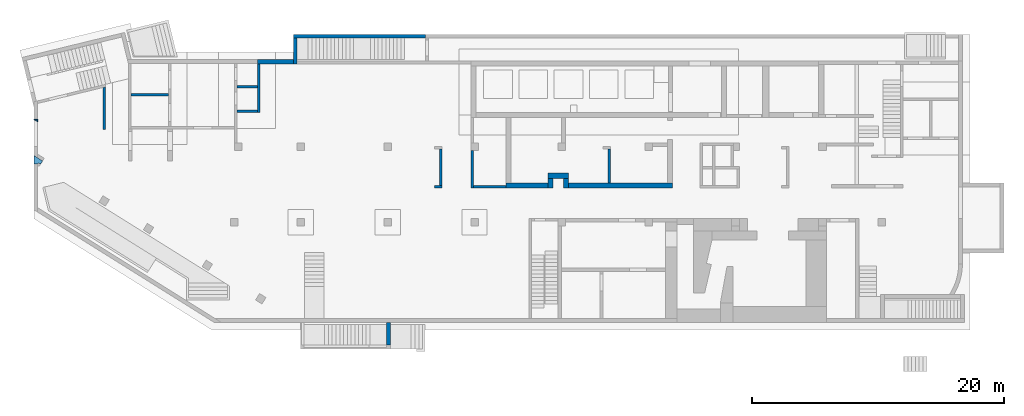
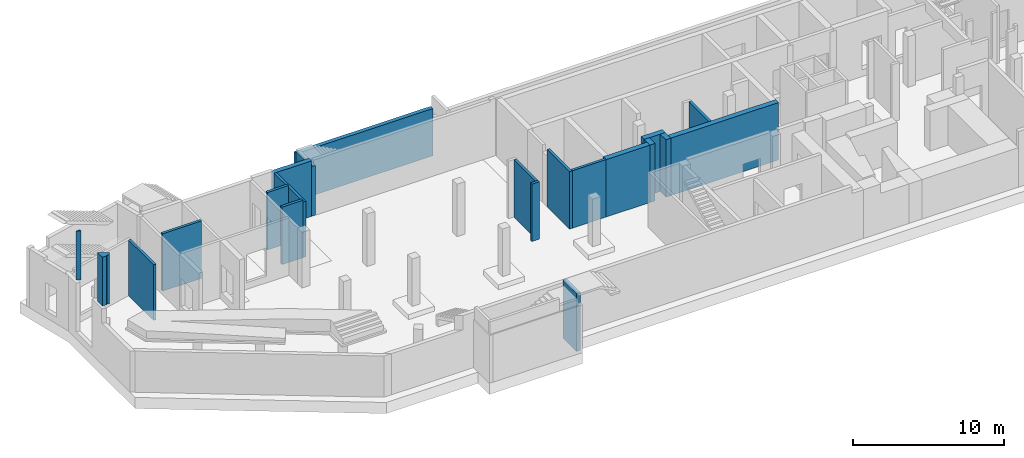
# One storey, part 2 of 9: 21 walls.
"""IFC4 building model written with IfcOpenShell, lengths in millimetres."""

from ifc_helpers import new_model, entity, si_unit, converted_unit, derived_unit, direction, frame, origin, place, context, subcontext, project, spatial, indexed_curve, outline, extrude, material, type_object, element, save


model = new_model("IFC4")

# Units and contexts
model_context = context("Model", 3, precision=0.01, world=origin(), true_north=direction((6.12303176911189e-17, 1.0)))
plan_context = context("Plan", 3, precision=0.01, world=origin(), true_north=direction((6.12303176911189e-17, 1.0)))
body_context = subcontext(model_context, "Body", "Model", "MODEL_VIEW")
ifc_project = project(units=[si_unit("LENGTHUNIT", "METRE", prefix="MILLI"), si_unit("AREAUNIT", "SQUARE_METRE"), si_unit("VOLUMEUNIT", "CUBIC_METRE"), converted_unit("PLANEANGLEUNIT", "DEGREE", entity("IfcRatioMeasure", 0.0174532925199433), si_unit("PLANEANGLEUNIT", "RADIAN"), dimensions=[0, 0, 0, 0, 0, 0, 0]), si_unit("MASSUNIT", "GRAM", prefix="KILO"), derived_unit("MASSDENSITYUNIT", [(si_unit("MASSUNIT", "GRAM", prefix="KILO"), 1), (si_unit("LENGTHUNIT", "METRE"), -3)]), derived_unit("MOMENTOFINERTIAUNIT", [(si_unit("LENGTHUNIT", "METRE"), 4)]), si_unit("TIMEUNIT", "SECOND"), si_unit("FREQUENCYUNIT", "HERTZ"), si_unit("THERMODYNAMICTEMPERATUREUNIT", "DEGREE_CELSIUS"), derived_unit("THERMALTRANSMITTANCEUNIT", [(si_unit("MASSUNIT", "GRAM", prefix="KILO"), 1), (si_unit("THERMODYNAMICTEMPERATUREUNIT", "KELVIN"), -1), (si_unit("TIMEUNIT", "SECOND"), -3)]), derived_unit("VOLUMETRICFLOWRATEUNIT", [(si_unit("LENGTHUNIT", "METRE"), 3), (si_unit("TIMEUNIT", "SECOND"), -1)]), derived_unit("MASSFLOWRATEUNIT", [(si_unit("MASSUNIT", "GRAM", prefix="KILO"), 1), (si_unit("TIMEUNIT", "SECOND"), -1)]), derived_unit("ROTATIONALFREQUENCYUNIT", [(si_unit("TIMEUNIT", "SECOND"), -1)]), si_unit("ELECTRICCURRENTUNIT", "AMPERE"), si_unit("ELECTRICVOLTAGEUNIT", "VOLT"), si_unit("POWERUNIT", "WATT"), si_unit("FORCEUNIT", "NEWTON", prefix="KILO"), si_unit("ILLUMINANCEUNIT", "LUX"), si_unit("LUMINOUSFLUXUNIT", "LUMEN"), si_unit("LUMINOUSINTENSITYUNIT", "CANDELA"), derived_unit("USERDEFINED", [(si_unit("MASSUNIT", "GRAM", prefix="KILO"), -1), (si_unit("LENGTHUNIT", "METRE"), -2), (si_unit("TIMEUNIT", "SECOND"), 3), (si_unit("LUMINOUSFLUXUNIT", "LUMEN"), 1)]), derived_unit("LINEARVELOCITYUNIT", [(si_unit("LENGTHUNIT", "METRE"), 1), (si_unit("TIMEUNIT", "SECOND"), -1)]), si_unit("PRESSUREUNIT", "PASCAL"), derived_unit("USERDEFINED", [(si_unit("LENGTHUNIT", "METRE"), -2), (si_unit("MASSUNIT", "GRAM", prefix="KILO"), 1), (si_unit("TIMEUNIT", "SECOND"), -2)]), derived_unit("LINEARFORCEUNIT", [(si_unit("MASSUNIT", "GRAM", prefix="KILO"), 1), (si_unit("LENGTHUNIT", "METRE"), 1), (si_unit("TIMEUNIT", "SECOND"), -2), (si_unit("LENGTHUNIT", "METRE"), -1)]), derived_unit("PLANARFORCEUNIT", [(si_unit("MASSUNIT", "GRAM", prefix="KILO"), 1), (si_unit("LENGTHUNIT", "METRE"), 1), (si_unit("TIMEUNIT", "SECOND"), -2), (si_unit("LENGTHUNIT", "METRE"), -2)])], contexts=[model_context, plan_context])

# Site, building, storey
site_placement = place(None, origin())
site = spatial("IfcSite", under=ifc_project, at=site_placement, CompositionType="ELEMENT")
building_placement = place(site_placement, origin())
building = spatial("IfcBuilding", under=site, at=building_placement, CompositionType="ELEMENT")
storey_placement = place(building_placement, frame((0.0, 0.0, -4900.0)))
storey = spatial("IfcBuildingStorey", under=building, at=storey_placement, CompositionType="ELEMENT", Elevation=-4900.0)

# Walls
ifc_material = material()
wall_type_1 = type_object("IfcWallType", Name=":ADSK_ 25_200", PredefinedType="STANDARD")
wall_1_placement = place(storey_placement, frame((34770.0, 13400.0, 0.0), z_axis=(0.0, 0.0, 1.0), x_axis=(0.0, -1.0, 0.0)))
element("IfcWall", 1, at=wall_1_placement, inside=storey, type_object=wall_type_1, material=ifc_material, Name=":ADSK_ 25_200", ObjectType=":ADSK_ 25_200", PredefinedType="NOTDEFINED", context=body_context, shape_type="SweptSolid", body=[
    extrude(outline(indexed_curve([(2975.00000000009, 99.9999999999989), (0.0, 99.9999999999989), (0.0, -99.9999999999989), (2975.00000000009, -99.9999999999989), (2975.00000000009, 99.9999999999989)], self_intersect=False)), origin(), (0.0, 0.0, 1.0), 4650.0),
])
wall_2_placement = place(storey_placement, frame((37465.0, 10525.0, 0.0), z_axis=(0.0, 0.0, 1.0), x_axis=(-1.0, 0.0, 0.0)))
element("IfcWall", 2, at=wall_2_placement, inside=storey, type_object=wall_type_1, material=ifc_material, Name=":ADSK_ 25_200", ObjectType=":ADSK_ 25_200", PredefinedType="NOTDEFINED", context=body_context, shape_type="SweptSolid", body=[
    extrude(outline(indexed_curve([(2595.00000000001, 99.9999999999988), (-2.45985829439147e-13, 99.9999999999989), (2.45985829439147e-13, -99.9999999999989), (2595.00000000001, -99.999999999999), (2595.00000000001, 99.9999999999988)], self_intersect=False)), origin(), (0.0, 0.0, 1.0), 4650.0),
])
wall_3_placement = place(storey_placement, frame((45670.0, 10825.0, 0.0), z_axis=(0.0, 0.0, 1.0), x_axis=(0.0, 1.0, 0.0)))
element("IfcWall", 3, at=wall_3_placement, inside=storey, type_object=wall_type_1, material=ifc_material, Name=":ADSK_ 25_200", ObjectType=":ADSK_ 25_200", PredefinedType="NOTDEFINED", context=body_context, shape_type="SweptSolid", body=[
    extrude(outline(indexed_curve([(2674.99999999998, 100.000000000003), (-3.01319549022173e-13, 100.000000000003), (3.01319549022173e-13, -100.000000000003), (2674.99999999998, -100.000000000004), (2674.99999999998, 100.000000000003)], self_intersect=False)), origin(), (0.0, 0.0, 1.0), 4650.0),
])
wall_4_placement = place(storey_placement, frame((32270.0, 10625.0, 0.0), z_axis=(0.0, 0.0, 1.0), x_axis=(0.0, 1.0, 0.0)))
element("IfcWall", 4, at=wall_4_placement, inside=storey, type_object=wall_type_1, material=ifc_material, Name=":ADSK_ 25_200", ObjectType=":ADSK_ 25_200", PredefinedType="NOTDEFINED", context=body_context, shape_type="SweptSolid", body=[
    extrude(outline(indexed_curve([(2875.0, 100.000000000001), (-2.09532179305615e-13, 99.9999999999989), (2.09532179305615e-13, -99.9999999999989), (2875.0, -99.9999999999972), (2875.0, 100.000000000001)], self_intersect=False)), origin(), (0.0, 0.0, 1.0), 4650.0),
])
wall_5_placement = place(storey_placement, frame((32370.0, 10525.0, 0.0), z_axis=(0.0, 0.0, 1.0), x_axis=(-1.0, 0.0, 0.0)))
element("IfcWall", 5, at=wall_5_placement, inside=storey, type_object=wall_type_1, material=ifc_material, Name=":ADSK_ 25_200", ObjectType=":ADSK_ 25_200", PredefinedType="NOTDEFINED", context=body_context, shape_type="SweptSolid", body=[
    extrude(outline(indexed_curve([(600.000000000001, 99.9999999999984), (-9.89300764987533e-13, 99.9999999999989), (9.89300764987533e-13, -99.9999999999989), (600.000000000003, -99.9999999999995), (600.000000000001, 99.9999999999984)], self_intersect=False)), origin(), (0.0, 0.0, 1.0), 4650.0),
])
wall_6_placement = place(storey_placement, frame((17825.0, 20250.0, 0.0), z_axis=(0.0, 0.0, 1.0), x_axis=(0.0, -1.0, 0.0)))
element("IfcWall", 6, at=wall_6_placement, inside=storey, type_object=wall_type_1, material=ifc_material, Name=":ADSK_ 25_200", ObjectType=":ADSK_ 25_200", PredefinedType="NOTDEFINED", context=body_context, shape_type="SweptSolid", body=[
    extrude(outline(indexed_curve([(3850.00000000022, 99.9999999999992), (-1.75600075021359e-13, 99.9999999999989), (1.75600075021359e-13, -99.9999999999989), (3850.00000000022, -99.9999999999987), (3850.00000000022, 99.9999999999992)], self_intersect=False)), origin(), (0.0, 0.0, 1.0), 4500.0),
])
wall_7_placement = place(storey_placement, frame((17725.0, 16500.0, 0.0), z_axis=(0.0, 0.0, 1.0), x_axis=(-1.0, 0.0, 0.0)))
element("IfcWall", 7, at=wall_7_placement, inside=storey, type_object=wall_type_1, material=ifc_material, Name=":ADSK_ 25_200", ObjectType=":ADSK_ 25_200", PredefinedType="NOTDEFINED", context=body_context, shape_type="SweptSolid", body=[
    extrude(outline(indexed_curve([(1624.99999999998, 99.9999999999989), (-2.66551908750373e-13, 99.9999999999989), (2.66551908750373e-13, -99.9999999999989), (1624.99999999998, -99.9999999999989), (1624.99999999998, 99.9999999999989)], self_intersect=False)), origin(), (0.0, 0.0, 1.0), 4650.0),
])
wall_8_placement = place(storey_placement, frame((10700.0, 17800.0, 0.0), z_axis=(0.0, 0.0, 1.0), x_axis=(-1.0, 0.0, 0.0)))
element("IfcWall", 8, at=wall_8_placement, inside=storey, type_object=wall_type_1, material=ifc_material, Name=":ADSK_ 25_200", ObjectType=":ADSK_ 25_200", PredefinedType="NOTDEFINED", context=body_context, shape_type="SweptSolid", body=[
    extrude(outline(indexed_curve([(3000.0, 99.9999999999983), (-3.4002868983536e-13, 99.9999999999989), (3.4002868983536e-13, -99.9999999999989), (3000.0, -99.9999999999995), (3000.0, 99.9999999999983)], self_intersect=False)), origin(), (0.0, 0.0, 1.0), 4650.0),
])
wall_9_placement = place(storey_placement, frame((17725.0, 18450.0, 0.0), z_axis=(0.0, 0.0, 1.0), x_axis=(-1.0, 0.0, 0.0)))
element("IfcWall", 9, at=wall_9_placement, inside=storey, type_object=wall_type_1, material=ifc_material, Name=":ADSK_ 25_200", ObjectType=":ADSK_ 25_200", PredefinedType="NOTDEFINED", context=body_context, shape_type="SweptSolid", body=[
    extrude(outline(indexed_curve([(1624.99999999999, 99.9999999999986), (-3.76649436277701e-13, 99.9999999999989), (3.76649436277701e-13, -99.9999999999989), (1624.99999999999, -99.9999999999993), (1624.99999999999, 99.9999999999986)], self_intersect=False)), origin(), (0.0, 0.0, 1.0), 4650.0),
])
wall_10_placement = place(storey_placement, frame((5600.0, 15073.13, 0.0), z_axis=(0.0, 0.0, 1.0), x_axis=(0.0, 1.0, 0.0)))
element("IfcWall", 10, at=wall_10_placement, inside=storey, type_object=wall_type_1, material=ifc_material, Name=":ADSK_ 25_200", ObjectType=":ADSK_ 25_200", PredefinedType="NOTDEFINED", context=body_context, shape_type="SweptSolid", body=[
    extrude(outline(indexed_curve([(3362.07130066753, -100.0), (3313.31918470919, 99.9999999999997), (-1.53224901010752e-13, 100.0), (1.53224901010752e-13, -100.0), (3362.07130066753, -100.0)], self_intersect=False)), origin(), (0.0, 0.0, 1.0), 4500.0),
])
wall_type_2 = type_object("IfcWallType", Name=":ADSK_ 25_300", PredefinedType="STANDARD")
wall_11_placement = place(storey_placement, frame((28140.0, -2250.0, 0.0), z_axis=(0.0, 0.0, 1.0), x_axis=(0.0, 1.0, 0.0)))
element("IfcWall", 11, at=wall_11_placement, inside=storey, type_object=wall_type_2, material=ifc_material, Name=":ADSK_ 25_300", ObjectType=":ADSK_ 25_300", PredefinedType="NOTDEFINED", context=body_context, shape_type="SweptSolid", body=[
    extrude(outline(indexed_curve([(1999.99999999999, -149.999999999999), (1999.99999999999, 150.000000000002), (200.000000000001, 150.000000000001), (200.0, -150.0), (1399.99999999983, -150.000000000001), (1999.99999999999, -149.999999999999)], self_intersect=False)), origin(), (0.0, 0.0, 1.0), 4700.0),
])
wall_12_placement = place(storey_placement, frame((20740.0, 20250.0, 0.0), z_axis=(0.0, 0.0, 1.0), x_axis=(0.0, 1.0, 0.0)))
element("IfcWall", 12, at=wall_12_placement, inside=storey, type_object=wall_type_2, material=ifc_material, Name=":ADSK_ 25_300", ObjectType=":ADSK_ 25_300", PredefinedType="NOTDEFINED", context=body_context, shape_type="SweptSolid", body=[
    extrude(outline(indexed_curve([(2049.99999999993, 150.000000000001), (0.0, 150.000000000001), (0.0, -150.000000000001), (2049.99999999993, -150.000000000001), (2049.99999999993, 150.000000000001)], self_intersect=False)), origin(), (0.0, 0.0, 1.0), 4035.0),
])
wall_13_placement = place(storey_placement, frame((31060.0, 22450.0, 0.0), z_axis=(0.0, 0.0, 1.0), x_axis=(-1.0, 0.0, 0.0)))
element("IfcWall", 13, at=wall_13_placement, inside=storey, type_object=wall_type_2, material=ifc_material, Name=":ADSK_ 25_300", ObjectType=":ADSK_ 25_300", PredefinedType="NOTDEFINED", context=body_context, shape_type="SweptSolid", body=[
    extrude(outline(indexed_curve([(10470.0, 149.999999999999), (-4.06075069700321e-13, 150.000000000001), (4.06075069700321e-13, -150.000000000001), (10470.0, -150.000000000003), (10470.0, 149.999999999999)], self_intersect=False)), origin(), (0.0, 0.0, 1.0), 3825.0),
])
wall_type_3 = type_object("IfcWallType", Name=":ADSK_ 25_400", PredefinedType="STANDARD")
wall_14_placement = place(storey_placement, frame((37465.0, 10625.0, 0.0)))
element("IfcWall", 14, at=wall_14_placement, inside=storey, type_object=wall_type_3, material=ifc_material, Name=":ADSK_ 25_400", ObjectType=":ADSK_ 25_400", PredefinedType="NOTDEFINED", context=body_context, shape_type="SweptSolid", body=[
    extrude(outline(indexed_curve([(3340.00000000001, 200.0), (-6.53955811791895e-13, 200.0), (6.53955811791895e-13, -200.0), (3340.00000000001, -200.0), (3340.00000000001, 200.0)], self_intersect=False)), origin(), (0.0, 0.0, 1.0), 4650.0),
])
wall_15_placement = place(storey_placement, frame((40805.0, 11385.0, 0.0)))
element("IfcWall", 15, at=wall_15_placement, inside=storey, type_object=wall_type_3, material=ifc_material, Name=":ADSK_ 25_400", ObjectType=":ADSK_ 25_400", PredefinedType="NOTDEFINED", context=body_context, shape_type="SweptSolid", body=[
    extrude(outline(indexed_curve([(1629.99999999998, 200.000000000001), (-6.30612781303807e-13, 200.0), (6.30612781303807e-13, -200.0), (1629.99999999999, -199.999999999999), (1629.99999999998, 200.000000000001)], self_intersect=False)), origin(), (0.0, 0.0, 1.0), 4650.0),
])
for number, where, z_axis, x_axis, name in (
    (16, (41005.0, 11185.0, 0.0), (0.0, 0.0, 1.0), (0.0, -1.0, 0.0), ":ADSK_ 25_400"),
    (17, (42235.0, 11185.0, 0.0), (0.0, 0.0, 1.0), (0.0, -1.0, 0.0), ":ADSK_ 25_400"),
):
    element("IfcWall", number, at=place(storey_placement, frame(where, z_axis=z_axis, x_axis=x_axis)), inside=storey, type_object=wall_type_3, material=ifc_material, Name=name, ObjectType=":ADSK_ 25_400", PredefinedType="NOTDEFINED", context=body_context, shape_type="SweptSolid", body=[
        extrude(outline(indexed_curve([(759.999999999996, 199.999999999998), (0.0, 199.999999999998), (0.0, -199.999999999998), (759.999999999996, -199.999999999998), (759.999999999996, 199.999999999998)], self_intersect=False)), origin(), (0.0, 0.0, 1.0), 4650.0),
    ])
wall_16_placement = place(storey_placement, frame((42435.0, 10625.0, 0.0)))
element("IfcWall", 18, at=wall_16_placement, inside=storey, type_object=wall_type_3, material=ifc_material, Name=":ADSK_ 25_400", ObjectType=":ADSK_ 25_400", PredefinedType="NOTDEFINED", context=body_context, shape_type="SweptSolid", body=[
    extrude(outline(indexed_curve([(8235.0, 200.000000000001), (-6.53955811791895e-13, 200.0), (6.53955811791895e-13, -200.0), (8235.0, -199.999999999999), (8235.0, 200.000000000001)], self_intersect=False)), origin(), (0.0, 0.0, 1.0), 4650.0),
])
wall_type_4 = type_object("IfcWallType", Name=":ADSK_ 25_350", PredefinedType="STANDARD")
wall_17_placement = place(storey_placement, frame((20740.0, 20425.0, 0.0), z_axis=(0.0, 0.0, 1.0), x_axis=(-1.0, 0.0, 0.0)))
element("IfcWall", 19, at=wall_17_placement, inside=storey, type_object=wall_type_4, material=ifc_material, Name=":ADSK_ 25_350", ObjectType=":ADSK_ 25_350", PredefinedType="NOTDEFINED", context=body_context, shape_type="SweptSolid", body=[
    extrude(outline(indexed_curve([(3015.00000000001, -174.999999999998), (3015.00000000001, 124.999999999834), (3015.00000000001, 175.0), (2815.00000000001, 175.0), (150.0, 175.0), (150.000000000001, -174.999999999999), (3015.00000000001, -174.999999999998)], self_intersect=False)), origin(), (0.0, 0.0, 1.0), 4500.0),
])
wall_type_5 = type_object("IfcWallType", Name="3: 3", PredefinedType="NOTDEFINED", material=ifc_material)
wall_18_placement = place(storey_placement, frame((0.21, 12305.12, 4750.0)))
element("IfcWall", 20, at=wall_18_placement, inside=storey, type_object=wall_type_5, material=ifc_material, Name="3: 3", ObjectType="3: 3", PredefinedType="NOTDEFINED", context=body_context, shape_type="SweptSolid", body=[
    extrude(outline(indexed_curve([(-131.231739163563, 98.4108115764556), (-393.432576023938, -46.9294855937384), (-74.3712552153423, -622.531345192431), (322.209288883721, 92.9040970677975), (234.747743375137, 141.385826175261), (59.824652357967, 238.349284390191), (-17.7461142139768, 98.4108115764556), (-131.231739163563, 98.4108115764556)], self_intersect=False)), frame((366.86, 179.46, 0.0), z_axis=(0.0, 0.0, -1.0), x_axis=(0.8746197071394, 0.48480962024633, 0.0)), (0.0, 0.0, -1.0), 3950.0),
])
wall_type_6 = type_object("IfcWallType", Name="4: 4", PredefinedType="NOTDEFINED", material=ifc_material)
wall_19_placement = place(storey_placement, frame((0.0, 15665.0, 4750.0)))
element("IfcWall", 21, at=wall_19_placement, inside=storey, type_object=wall_type_6, material=ifc_material, Name="4: 4", ObjectType="4: 4", PredefinedType="NOTDEFINED", context=body_context, shape_type="SweptSolid", body=[
    extrude(outline(indexed_curve([(-124.971431388, -100.0), (62.4857156940014, -100.0), (62.4857156940009, 200.0), (-124.971431388, -100.0)], self_intersect=False)), frame((200.0, 124.97, 0.0), z_axis=(0.0, 0.0, 1.0), x_axis=(0.0, 1.0, 0.0)), (0.0, 0.0, 1.0), 3950.0),
])

save(model, "model.ifc")
